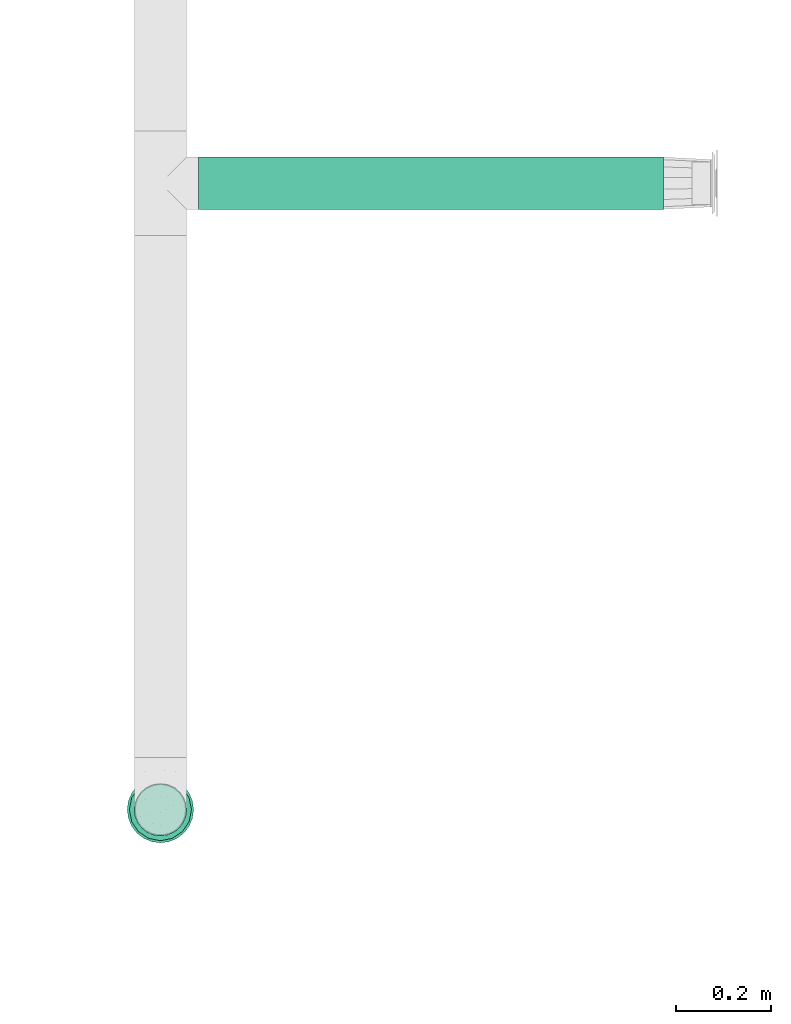
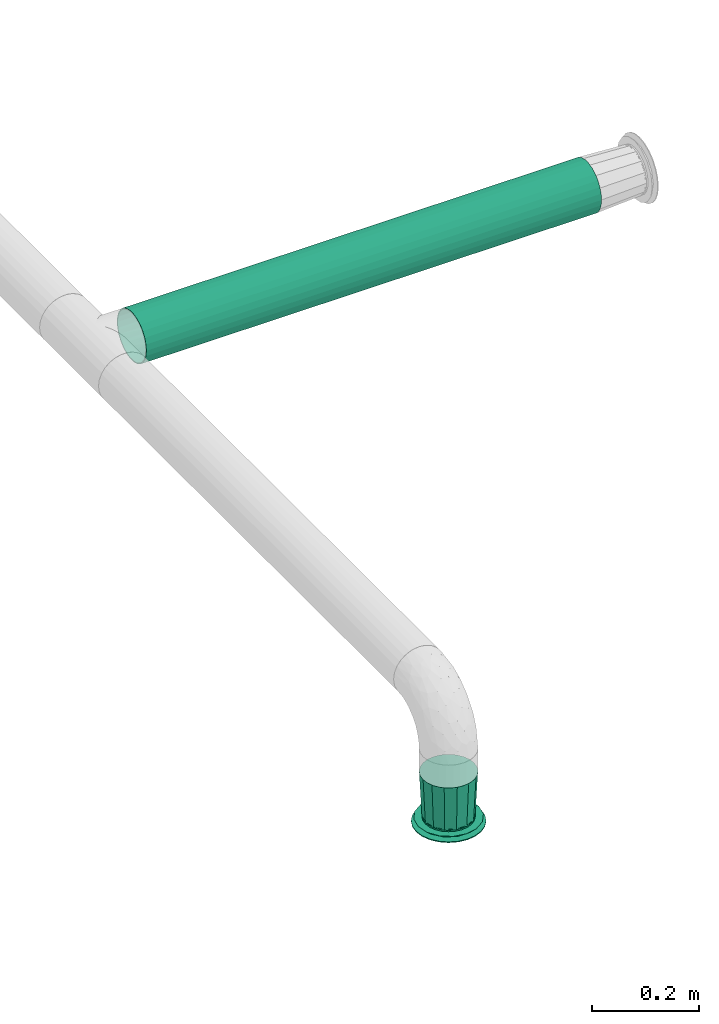
# One storey, part 80 of 115: 1 flow fitting, 1 flow segment, 1 flow terminal.
"""IFC2X3 building model written with IfcOpenShell, lengths in millimetres."""

from ifc_helpers import new_model, entity, si_unit, converted_unit, derived_unit, direction, frame, origin_with_axes, origin_2d_with_axis, place, context, subcontext, project, spatial, hollow_circle, extrude, open_shell, surface_model, source, transform, mapped, material, layer, layer_set, layer_usage, type_object, element, save


model = new_model("IFC2X3")

# Units and contexts
model_context = context("Model", 3, precision=1e-05, world=origin_with_axes(), true_north=direction((0.0, 1.0)))
body_context = subcontext(model_context, "Body", "Model", "MODEL_VIEW")
ifc_project = project(units=[si_unit("AREAUNIT", "SQUARE_METRE"), si_unit("VOLUMEUNIT", "CUBIC_METRE", prefix="DECI"), si_unit("TIMEUNIT", "SECOND"), si_unit("THERMODYNAMICTEMPERATUREUNIT", "DEGREE_CELSIUS"), si_unit("PRESSUREUNIT", "PASCAL"), si_unit("MASSUNIT", "GRAM", prefix="KILO"), si_unit("LENGTHUNIT", "METRE", prefix="MILLI"), si_unit("POWERUNIT", "WATT"), si_unit("ELECTRICCURRENTUNIT", "AMPERE"), si_unit("ELECTRICVOLTAGEUNIT", "VOLT"), derived_unit("VOLUMETRICFLOWRATEUNIT", [(si_unit("VOLUMEUNIT", "CUBIC_METRE", prefix="DECI"), 1), (si_unit("TIMEUNIT", "SECOND"), -1)]), derived_unit("LINEARVELOCITYUNIT", [(si_unit("LENGTHUNIT", "METRE"), 1), (si_unit("TIMEUNIT", "SECOND"), -1)]), derived_unit("MASSDENSITYUNIT", [(si_unit("MASSUNIT", "GRAM", prefix="KILO"), 1), (si_unit("VOLUMEUNIT", "CUBIC_METRE"), -1)]), converted_unit("PLANEANGLEUNIT", "DEGREE", entity("IfcRatioMeasure", 0.01745), si_unit("PLANEANGLEUNIT", "RADIAN"), dimensions=[0, 0, 0, 0, 0, 0, 0])], contexts=[model_context])

# Site, building, storey
site_placement = place(None, origin_with_axes())
site = spatial("IfcSite", under=ifc_project, at=site_placement, CompositionType="ELEMENT")
building_placement = place(site_placement, origin_with_axes())
building = spatial("IfcBuilding", under=site, at=building_placement, Name="mc-building", CompositionType="ELEMENT")
storey_placement = place(building_placement, frame((0.0, 0.0, 2950.0), z_axis=(0.0, 0.0, 1.0), x_axis=(1.0, 0.0, 0.0)))
storey = spatial("IfcBuildingStorey", under=building, at=storey_placement, Name="2. Korrus", CompositionType="ELEMENT", Elevation=2950.0)

# Flow terminal
air_terminal_type = type_object("IfcAirTerminalType", Name="100", PredefinedType="NOTDEFINED")
shared_shape_1 = source(origin_with_axes(), body_context, "Body", "SurfaceModel", [
    surface_model("IfcShellBasedSurfaceModel", [(11.2, -70.0, 0.0), (11.2, -67.61481, -18.11733), (11.2, -67.61481, 18.11733), (6.2, -14.64625, -20.15883), (9.2, -22.36867, -22.36867), (6.2, -21.19625, -15.39997), (9.2, 16.375, -28.36233), (6.2, 8.09625, -24.91768), (6.2, 14.64625, -20.15883), (6.2, -8.09625, -24.91768), (9.2, -16.375, -28.36233), (6.2, 21.19625, -15.39997), (9.2, 22.36867, -22.36867), (9.2, -8.1875, -30.55617), (9.2, 8.1875, -30.55617), (9.2, 28.36233, -16.375), (9.2, -28.36233, -16.375), (6.2, 14.64625, 20.15883), (9.2, 22.36867, 22.36867), (6.2, 21.19625, 15.39997), (9.2, -16.375, 28.36233), (6.2, -8.09625, 24.91768), (6.2, -14.64625, 20.15883), (6.2, 8.09625, 24.91768), (9.2, 16.375, 28.36233), (6.2, -21.19625, 15.39997), (9.2, -22.36867, 22.36867), (9.2, 8.1875, 30.55617), (9.2, -8.1875, 30.55617), (9.2, -28.36233, 16.375), (9.2, 28.36233, 16.375), (6.2, -53.11211, -25.57744), (6.2, -36.75472, -46.08897), (6.2, -13.11761, -57.472), (6.2, 13.11761, -57.472), (6.2, 36.75472, -46.08897), (6.2, 53.11211, -25.57744), (0.0, -12.53288, -63.00706), (6.2, 0.0, -57.472), (0.0, -46.3155, -46.3155), (0.0, -35.69063, -53.4148), (0.0, 0.0, -65.5), (6.2, 44.93342, -35.83321), (0.0, 46.3155, -46.3155), (0.0, 35.69063, -53.4148), (6.2, -44.93342, -35.83321), (0.0, 12.53288, -63.00706), (0.0, 25.06576, -60.51411), (6.2, 56.03105, -12.78872), (0.0, 60.51411, -25.06576), (0.0, 63.00706, -12.53288), (0.0, 53.4148, -35.69063), (0.0, -25.06576, -60.51411), (0.0, -63.00706, -12.53288), (0.0, -60.51411, -25.06576), (6.2, -56.03105, -12.78872), (0.0, -53.4148, -35.69063), (6.2, 13.11761, 57.472), (0.0, 12.53288, 63.00706), (6.2, 0.0, 57.472), (6.2, 36.75472, 46.08897), (0.0, 46.3155, 46.3155), (0.0, 35.69063, 53.4148), (0.0, 0.0, 65.5), (6.2, -44.93342, 35.83321), (6.2, -36.75472, 46.08897), (0.0, -46.3155, 46.3155), (0.0, -35.69063, 53.4148), (6.2, 44.93342, 35.83321), (0.0, -12.53288, 63.00706), (0.0, -25.06576, 60.51411), (6.2, -13.11761, 57.472), (6.2, -56.03105, 12.78872), (0.0, -60.51411, 25.06576), (0.0, -63.00706, 12.53288), (0.0, -53.4148, 35.69063), (0.0, 25.06576, 60.51411), (0.0, 63.00706, 12.53288), (0.0, 60.51411, 25.06576), (6.2, 56.03105, 12.78872), (0.0, 53.4148, 35.69063), (-3.1, 43.30127, 25.0), (-3.1, -48.29629, -12.94095), (-3.1, -43.30127, 25.0), (-3.1, 25.0, -43.30127), (-3.1, 48.29629, -12.94095), (-3.1, 35.35534, -35.35534), (-3.1, -35.35534, -35.35534), (-3.1, -25.0, -43.30127), (-43.1, 43.46666, 11.64686), (-3.1, 38.97115, 22.5), (-3.1, 43.46666, 11.64686), (-3.1, 45.0, 0.0), (-43.1, 45.0, 0.0), (-3.1, 31.81981, 31.81981), (-43.1, 38.97115, 22.5), (-43.1, -38.97115, 22.5), (-3.1, -38.97115, 22.5), (-3.1, -31.81981, 31.81981), (-3.1, -43.46666, 11.64686), (-43.1, -43.46666, 11.64686), (-43.1, -45.0, 0.0), (-3.1, -45.0, 0.0), (-43.1, -43.46666, -11.64686), (-3.1, -38.97115, -22.5), (-3.1, -43.46666, -11.64686), (-3.1, -11.64686, -43.46666), (-3.1, -22.5, -38.97115), (-43.1, -22.5, -38.97115), (-3.1, -31.81981, -31.81981), (-43.1, -38.97115, -22.5), (-43.1, 22.5, -38.97115), (-3.1, 22.5, -38.97115), (-3.1, 11.64686, -43.46666), (-43.1, 38.97115, -22.5), (-3.1, 38.97115, -22.5), (-3.1, 31.81981, -31.81981), (-3.1, 43.46666, -11.64686), (-43.1, 43.46666, -11.64686), (11.2, -49.49747, -49.49747), (11.2, -35.0, -60.62178), (11.2, -18.11733, -67.61481), (11.2, 67.61481, 18.11733), (11.2, -60.62178, -35.0), (11.2, 18.11733, -67.61481), (11.2, 35.0, -60.62178), (11.2, 0.0, -70.0), (11.2, 60.62178, -35.0), (11.2, 67.61481, -18.11733), (11.2, 49.49747, -49.49747), (11.2, -49.49747, 49.49747), (11.2, -60.62178, 35.0), (11.2, -35.0, 60.62178), (11.2, -18.11733, 67.61481), (11.2, 0.0, 70.0), (11.2, 60.62178, 35.0), (11.2, 49.49747, 49.49747), (11.2, 70.0, 0.0), (11.2, 35.0, 60.62178), (11.2, 18.11733, 67.61481), (9.2, -49.49747, 49.49747), (9.2, -35.0, 60.62178), (9.2, -18.11733, 67.61481), (9.2, -67.61481, 18.11733), (9.2, -70.0, 0.0), (9.2, -60.62178, 35.0), (9.2, 67.61481, 18.11733), (9.2, 35.0, 60.62178), (9.2, 18.11733, 67.61481), (9.2, 0.0, 70.0), (9.2, 60.62178, 35.0), (9.2, 49.49747, 49.49747), (9.2, -67.61481, -18.11733), (9.2, -49.49747, -49.49747), (9.2, -60.62178, -35.0), (9.2, -18.11733, -67.61481), (9.2, 70.0, 0.0), (9.2, -35.0, -60.62178), (9.2, 0.0, -70.0), (9.2, 60.62178, -35.0), (9.2, 49.49747, -49.49747), (9.2, 67.61481, -18.11733), (9.2, 35.0, -60.62178), (9.2, 18.11733, -67.61481), (9.2, -32.75, 0.0), (9.2, 0.0, 32.75), (9.2, 32.75, 0.0), (9.2, 0.0, -32.75), (6.2, 26.2, 0.0), (6.2, -26.2, 0.0), (9.2, -31.06579, -6.28555), (6.2, -23.69812, -7.69999), (6.2, 23.69812, -7.69999), (9.2, 31.06579, -6.28555), (6.2, 0.0, -24.91768), (9.2, 31.06579, 6.28555), (6.2, 23.69812, 7.69999), (6.2, -23.69812, 7.69999), (9.2, -31.06579, 6.28555), (6.2, 0.0, 24.91768), (6.2, 53.11211, 25.57744), (6.2, 58.95, 0.0), (6.2, -53.11211, 25.57744), (6.2, -58.95, 0.0), (0.0, 65.5, 0.0), (0.0, -65.5, 0.0), (6.2, -24.93616, -51.78048), (6.2, 24.93616, -51.78048), (6.2, 24.93616, 51.78048), (6.2, -24.93616, 51.78048), (-3.1, 0.0, 50.0), (-3.1, 35.35534, 35.35534), (-3.1, -12.94095, 48.29629), (-3.1, -25.0, 43.30127), (-3.1, -35.35534, 35.35534), (-3.1, 25.0, 43.30127), (-3.1, 12.94095, 48.29629), (-3.1, 48.29629, 12.94095), (-3.1, 50.0, 0.0), (-3.1, -50.0, 0.0), (-3.1, -48.29629, 12.94095), (-3.1, -43.30127, -25.0), (-3.1, -12.94095, -48.29629), (-3.1, 0.0, -50.0), (-3.1, 43.30127, -25.0), (-3.1, 12.94095, -48.29629), (0.0, -12.94095, -48.29629), (0.0, 0.0, -50.0), (0.0, -25.0, -43.30127), (0.0, -35.35534, -35.35534), (0.0, -48.29629, -12.94095), (0.0, 25.0, -43.30127), (0.0, -43.30127, -25.0), (0.0, 43.30127, 25.0), (0.0, 12.94095, -48.29629), (0.0, 43.30127, -25.0), (0.0, 48.29629, -12.94095), (0.0, 35.35534, -35.35534), (0.0, 50.0, 0.0), (0.0, -50.0, 0.0), (0.0, -48.29629, 12.94095), (0.0, -43.30127, 25.0), (0.0, -35.35534, 35.35534), (0.0, -12.94095, 48.29629), (0.0, -25.0, 43.30127), (0.0, 35.35534, 35.35534), (0.0, 0.0, 50.0), (0.0, 48.29629, 12.94095), (0.0, 25.0, 43.30127), (0.0, 12.94095, 48.29629), (-43.1, -22.5, 38.97115), (-43.1, -11.64686, 43.46666), (-43.1, 0.0, 45.0), (-43.1, 11.64686, 43.46666), (-43.1, -31.81981, 31.81981), (-43.1, 31.81981, 31.81981), (-43.1, 22.5, 38.97115), (-43.1, -31.81981, -31.81981), (-43.1, 31.81981, -31.81981), (-43.1, -11.64686, -43.46666), (-43.1, 11.64686, -43.46666), (-43.1, 0.0, -45.0), (-3.1, 0.0, -45.0), (-3.1, 0.0, 45.0), (-3.1, -22.5, 38.97115), (-3.1, -11.64686, 43.46666), (-3.1, 11.64686, 43.46666), (-3.1, 22.5, 38.97115)], [open_shell([[[0, 1, 2]], [[3, 4, 5]], [[6, 7, 8]], [[3, 9, 10]], [[4, 3, 10]], [[11, 12, 8]], [[13, 10, 9]], [[7, 6, 14]], [[6, 8, 12]], [[12, 11, 15]], [[16, 5, 4]], [[17, 18, 19]], [[20, 21, 22]], [[17, 23, 24]], [[18, 17, 24]], [[25, 26, 22]], [[27, 24, 23]], [[21, 20, 28]], [[20, 22, 26]], [[26, 25, 29]], [[30, 19, 18]], [[31, 32, 33]], [[34, 35, 36]], [[33, 37, 38]], [[32, 39, 40]], [[41, 38, 37]], [[42, 35, 43]], [[44, 43, 35]], [[39, 32, 45]], [[46, 47, 34]], [[48, 49, 50]], [[38, 46, 34]], [[42, 43, 51]], [[33, 52, 37]], [[53, 54, 55]], [[46, 38, 41]], [[56, 39, 45]], [[57, 58, 59]], [[60, 61, 62]], [[63, 59, 58]], [[64, 65, 66]], [[67, 66, 65]], [[61, 60, 68]], [[69, 70, 71]], [[72, 73, 74]], [[59, 69, 71]], [[64, 66, 75]], [[57, 76, 58]], [[77, 78, 79]], [[69, 59, 63]], [[80, 61, 68]], [[81, 82, 83]], [[84, 85, 86]], [[87, 82, 88]], [[89, 90, 91]], [[91, 92, 93]], [[94, 90, 95]], [[96, 97, 98]], [[99, 97, 100]], [[101, 102, 99]], [[103, 104, 105]], [[105, 102, 101]], [[106, 107, 108]], [[109, 104, 110]], [[111, 112, 113]], [[114, 115, 116]], [[117, 115, 118]], [[93, 92, 117]], [[119, 120, 121]], [[1, 119, 121]], [[122, 1, 121]], [[123, 119, 1]], [[124, 122, 121]], [[125, 122, 124]], [[121, 126, 124]], [[127, 128, 129]], [[129, 128, 122]], [[129, 122, 125]], [[130, 131, 2]], [[132, 130, 2]], [[122, 133, 2]], [[132, 2, 133]], [[134, 133, 122]], [[135, 136, 122]], [[122, 128, 137]], [[136, 138, 122]], [[139, 122, 138]], [[122, 139, 134]], [[2, 1, 122]], [[140, 141, 142]], [[143, 140, 142]], [[142, 144, 143]], [[145, 140, 143]], [[146, 144, 142]], [[147, 146, 148]], [[149, 148, 146]], [[150, 146, 151]], [[147, 151, 146]], [[146, 142, 149]], [[146, 152, 144]], [[153, 154, 152]], [[155, 153, 152]], [[146, 156, 155]], [[157, 153, 155]], [[158, 155, 156]], [[159, 160, 161]], [[156, 161, 160]], [[160, 162, 156]], [[163, 156, 162]], [[163, 158, 156]], [[152, 146, 155]], [[156, 128, 161]], [[161, 127, 159]], [[162, 160, 125]], [[129, 160, 159]], [[163, 162, 124]], [[128, 127, 161]], [[156, 137, 128]], [[162, 125, 124]], [[125, 160, 129]], [[159, 127, 129]], [[163, 124, 126]], [[126, 158, 163]], [[158, 121, 155]], [[155, 120, 157]], [[154, 153, 123]], [[119, 153, 157]], [[152, 154, 1]], [[120, 119, 157]], [[155, 121, 120]], [[152, 1, 0]], [[1, 154, 123]], [[153, 119, 123]], [[152, 0, 144]], [[126, 121, 158]], [[144, 2, 143]], [[143, 131, 145]], [[141, 140, 132]], [[130, 140, 145]], [[142, 141, 133]], [[2, 131, 143]], [[144, 0, 2]], [[141, 132, 133]], [[132, 140, 130]], [[145, 131, 130]], [[142, 133, 134]], [[134, 149, 142]], [[149, 139, 148]], [[148, 138, 147]], [[150, 151, 135]], [[136, 151, 147]], [[146, 150, 122]], [[138, 136, 147]], [[148, 139, 138]], [[146, 122, 137]], [[122, 150, 135]], [[151, 136, 135]], [[146, 137, 156]], [[134, 139, 149]], [[30, 24, 164]], [[24, 20, 164]], [[165, 20, 24]], [[164, 20, 29]], [[166, 30, 16]], [[16, 6, 166]], [[167, 6, 10]], [[30, 164, 16]], [[10, 6, 16]], [[6, 15, 166]], [[21, 19, 11]], [[23, 19, 21]], [[11, 19, 168]], [[7, 25, 21]], [[7, 5, 169]], [[21, 11, 7]], [[9, 5, 7]], [[169, 25, 7]], [[170, 164, 169]], [[170, 171, 16]], [[11, 172, 15]], [[172, 168, 173]], [[174, 13, 9]], [[166, 173, 168]], [[172, 173, 15]], [[169, 171, 170]], [[5, 16, 171]], [[167, 174, 14]], [[174, 167, 13]], [[14, 174, 7]], [[175, 166, 168]], [[175, 176, 30]], [[25, 177, 29]], [[177, 169, 178]], [[179, 27, 23]], [[164, 178, 169]], [[177, 178, 29]], [[168, 176, 175]], [[19, 30, 176]], [[165, 179, 28]], [[179, 165, 27]], [[28, 179, 21]], [[180, 60, 57]], [[181, 180, 65]], [[65, 57, 71]], [[180, 57, 65]], [[65, 182, 181]], [[182, 36, 181]], [[183, 34, 36]], [[31, 34, 183]], [[31, 33, 34]], [[182, 183, 36]], [[70, 63, 49]], [[70, 73, 66]], [[49, 63, 184]], [[78, 76, 61]], [[76, 78, 184]], [[184, 63, 76]], [[73, 70, 49]], [[39, 54, 185]], [[41, 39, 185]], [[52, 39, 41]], [[43, 185, 49]], [[185, 43, 47]], [[185, 47, 41]], [[73, 49, 185]], [[55, 54, 31]], [[31, 54, 56]], [[52, 186, 40]], [[53, 55, 183]], [[56, 45, 31]], [[185, 53, 183]], [[32, 40, 186]], [[33, 186, 52]], [[44, 35, 187]], [[49, 36, 51]], [[34, 47, 187]], [[42, 51, 36]], [[187, 47, 44]], [[49, 48, 36]], [[48, 50, 181]], [[184, 181, 50]], [[79, 78, 180]], [[180, 78, 80]], [[76, 188, 62]], [[77, 79, 181]], [[80, 68, 180]], [[184, 77, 181]], [[60, 62, 188]], [[57, 188, 76]], [[67, 65, 189]], [[73, 182, 75]], [[71, 70, 189]], [[64, 75, 182]], [[189, 70, 67]], [[73, 72, 182]], [[72, 74, 183]], [[185, 183, 74]], [[190, 191, 192]], [[193, 192, 194]], [[83, 192, 81]], [[194, 192, 83]], [[195, 191, 196]], [[191, 190, 196]], [[197, 198, 81]], [[81, 192, 191]], [[198, 84, 81]], [[199, 200, 83]], [[81, 88, 82]], [[201, 82, 87]], [[88, 81, 202]], [[81, 203, 202]], [[204, 86, 85]], [[205, 203, 84]], [[84, 198, 85]], [[81, 84, 203]], [[199, 83, 82]], [[206, 207, 208]], [[209, 208, 210]], [[210, 208, 211]], [[212, 209, 210]], [[210, 211, 213]], [[214, 211, 207]], [[211, 208, 207]], [[215, 216, 217]], [[211, 217, 216]], [[216, 218, 211]], [[219, 210, 220]], [[221, 210, 213]], [[222, 221, 223]], [[213, 223, 221]], [[224, 222, 223]], [[223, 225, 226]], [[227, 213, 218]], [[218, 213, 211]], [[228, 229, 225]], [[223, 213, 225]], [[226, 225, 229]], [[221, 220, 210]], [[199, 220, 200]], [[200, 221, 83]], [[193, 194, 224]], [[222, 194, 83]], [[192, 193, 223]], [[220, 221, 200]], [[199, 219, 220]], [[193, 224, 223]], [[224, 194, 222]], [[83, 221, 222]], [[192, 223, 226]], [[226, 190, 192]], [[190, 229, 196]], [[196, 228, 195]], [[81, 191, 213]], [[225, 191, 195]], [[197, 81, 227]], [[228, 225, 195]], [[196, 229, 228]], [[197, 227, 218]], [[227, 81, 213]], [[191, 225, 213]], [[197, 218, 198]], [[226, 229, 190]], [[198, 216, 85]], [[85, 215, 204]], [[84, 86, 211]], [[217, 86, 204]], [[205, 84, 214]], [[216, 215, 85]], [[198, 218, 216]], [[84, 211, 214]], [[211, 86, 217]], [[204, 215, 217]], [[205, 214, 207]], [[207, 203, 205]], [[203, 206, 202]], [[202, 208, 88]], [[201, 87, 212]], [[209, 87, 88]], [[82, 201, 210]], [[208, 209, 88]], [[202, 206, 208]], [[82, 210, 219]], [[210, 201, 212]], [[87, 209, 212]], [[82, 219, 199]], [[207, 206, 203]], [[230, 231, 232]], [[230, 232, 233]], [[230, 100, 96]], [[234, 230, 96]], [[100, 230, 233]], [[235, 89, 236]], [[100, 233, 236]], [[95, 89, 235]], [[118, 89, 93]], [[118, 236, 89]], [[118, 100, 236]], [[110, 103, 101]], [[237, 110, 101]], [[238, 108, 101]], [[237, 101, 108]], [[239, 108, 238]], [[114, 238, 118]], [[238, 101, 118]], [[240, 241, 111]], [[238, 111, 241]], [[238, 241, 239]], [[100, 118, 101]], [[106, 242, 107]], [[107, 112, 109]], [[102, 105, 104]], [[112, 104, 109]], [[92, 104, 117]], [[113, 112, 242]], [[112, 107, 242]], [[115, 117, 116]], [[112, 116, 117]], [[112, 117, 104]], [[92, 102, 104]], [[97, 99, 243]], [[98, 97, 244]], [[243, 245, 244]], [[97, 243, 244]], [[246, 243, 99]], [[90, 94, 91]], [[92, 91, 247]], [[94, 247, 91]], [[247, 99, 92]], [[247, 246, 99]], [[102, 92, 99]], [[101, 99, 100]], [[100, 97, 96]], [[230, 234, 244]], [[98, 234, 96]], [[231, 230, 245]], [[245, 230, 244]], [[244, 234, 98]], [[245, 243, 231]], [[243, 232, 231]], [[236, 233, 246]], [[236, 247, 235]], [[89, 95, 90]], [[94, 95, 235]], [[93, 89, 91]], [[232, 246, 233]], [[246, 247, 236]], [[243, 246, 232]], [[247, 94, 235]], [[93, 117, 118]], [[118, 115, 114]], [[111, 238, 112]], [[116, 238, 114]], [[240, 111, 113]], [[112, 238, 116]], [[240, 113, 242]], [[242, 241, 240]], [[108, 239, 106]], [[108, 107, 237]], [[103, 110, 104]], [[109, 110, 237]], [[101, 103, 105]], [[241, 106, 239]], [[242, 106, 241]], [[107, 109, 237]]])]),
])
flow_terminal_placement = place(storey_placement, frame((18604.54349, 8183.57591, 2200.0), z_axis=(0.0, 1.0, 0.0), x_axis=(0.0, 0.0, -1.0)))
element("IfcFlowTerminal", 1, at=flow_terminal_placement, inside=storey, type_object=air_terminal_type, Name="100", context=body_context, shape_type="MappedRepresentation", body=[
    mapped(shared_shape_1, transform((0.0, 0.0, 0.0), scale=1.0)),
])

# Flow fitting
duct_fitting_type = type_object("IfcDuctFittingType", PredefinedType="TRANSITION")
shared_shape_2 = source(origin_with_axes(), body_context, "Body", "SurfaceModel", [
    surface_model("IfcShellBasedSurfaceModel", [(100.0, -55.0, 0.0), (100.0, -12.23865, 53.62104), (100.0, -34.29194, 43.00073), (100.0, 49.55329, 23.86361), (100.0, 34.29194, 43.00073), (100.0, 49.55329, -23.86361), (0.0, -45.04844, -21.69419), (0.0, -50.0, 0.0), (0.0, -45.04844, 21.69419), (0.0, 31.17449, 39.09157), (0.0, 45.04844, 21.69419), (0.0, 50.0, 0.0), (98.0, 47.63139, 27.5), (98.0, 0.0, 55.0), (98.0, 38.89087, 38.89087), (98.0, -38.89087, 38.89087), (98.0, -47.63139, 27.5), (100.0, 12.23865, 53.62104), (100.0, -49.55329, 23.86361), (100.0, 55.0, 0.0), (100.0, 12.23865, -53.62104), (100.0, 34.29194, -43.00073), (100.0, -49.55329, -23.86361), (100.0, -34.29194, -43.00073), (100.0, -12.23865, -53.62104), (0.0, -31.17449, 39.09157), (0.0, -11.12605, 48.7464), (0.0, 11.12605, 48.7464), (0.0, -31.17449, -39.09157), (0.0, 11.12605, -48.7464), (0.0, -11.12605, -48.7464), (0.0, 45.04844, -21.69419), (0.0, 31.17449, -39.09157), (0.0, 47.52422, -10.84709), (0.0, 38.11147, -30.39288), (100.0, 41.92261, -33.43217), (100.0, -41.92261, -33.43217), (0.0, -38.11147, -30.39288), (100.0, 23.2653, -48.31088), (0.0, 21.15027, -43.91899), (100.0, 52.32388, -11.72483), (0.0, 0.0, -48.7464), (100.0, 0.0, -53.62104), (0.0, -21.15027, -43.91899), (100.0, -23.2653, -48.31088), (0.0, -47.52422, -10.84709), (100.0, -52.32388, -11.72483), (0.0, -47.52422, 10.84709), (0.0, -38.11147, 30.39288), (100.0, -41.92261, 33.43217), (100.0, 41.92261, 33.43217), (0.0, 38.11147, 30.39288), (100.0, -23.2653, 48.31088), (0.0, -21.15027, 43.91899), (100.0, -52.32388, 11.72483), (0.0, 0.0, 48.7464), (100.0, 0.0, 53.62104), (0.0, 21.15027, 43.91899), (100.0, 23.2653, 48.31088), (0.0, 47.52422, 10.84709), (100.0, 52.32388, 11.72483), (100.0, -14.23505, -53.12592), (100.0, 0.0, -55.0), (100.0, -27.5, -47.63139), (100.0, 27.5, -47.63139), (100.0, -38.89087, -38.89087), (100.0, -53.12592, -14.23505), (100.0, -47.63139, -27.5), (100.0, -47.63139, 27.5), (100.0, 14.23505, -53.12592), (100.0, 38.89087, -38.89087), (100.0, 47.63139, -27.5), (100.0, 47.63139, 27.5), (100.0, 53.12592, -14.23505), (100.0, -53.12592, 14.23505), (100.0, -38.89087, 38.89087), (100.0, -27.5, 47.63139), (100.0, 0.0, 55.0), (100.0, -14.23505, 53.12592), (100.0, 53.12592, 14.23505), (100.0, 38.89087, 38.89087), (100.0, 27.5, 47.63139), (100.0, 14.23505, 53.12592), (98.0, -27.5, 47.63139), (98.0, -14.23505, 53.12592), (98.0, -53.12592, -14.23505), (98.0, 14.23505, 53.12592), (98.0, 27.5, 47.63139), (98.0, 53.12592, 14.23505), (98.0, 55.0, 0.0), (98.0, -47.63139, -27.5), (98.0, -53.12592, 14.23505), (98.0, 27.5, -47.63139), (98.0, -27.5, -47.63139), (98.0, -38.89087, -38.89087), (98.0, 0.0, -55.0), (98.0, -14.23505, -53.12592), (98.0, 38.89087, -38.89087), (98.0, 47.63139, -27.5), (98.0, 53.12592, -14.23505), (98.0, 14.23505, -53.12592), (98.0, -55.0, 0.0), (0.0, 0.0, 50.0), (0.0, 35.35534, 35.35534), (0.0, -12.94095, 48.29629), (0.0, -25.0, 43.30127), (0.0, -35.35534, 35.35534), (0.0, -48.29629, 12.94095), (0.0, -43.30127, 25.0), (0.0, 25.0, 43.30127), (0.0, 12.94095, 48.29629), (0.0, 43.30127, 25.0), (0.0, 48.29629, 12.94095), (0.0, 25.0, -43.30127), (0.0, 48.29629, -12.94095), (0.0, -48.29629, -12.94095), (0.0, -43.30127, -25.0), (0.0, -12.94095, -48.29629), (0.0, -25.0, -43.30127), (0.0, -35.35534, -35.35534), (0.0, 43.30127, -25.0), (0.0, 35.35534, -35.35534), (0.0, 12.94095, -48.29629), (0.0, 0.0, -50.0), (2.0, -35.35534, -35.35534), (2.0, -25.0, -43.30127), (2.0, -12.94095, -48.29629), (2.0, -43.30127, -25.0), (2.0, 0.0, -50.0), (2.0, -48.29629, -12.94095), (2.0, -50.0, 0.0), (2.0, 12.94095, -48.29629), (2.0, 25.0, -43.30127), (2.0, 43.30127, -25.0), (2.0, 48.29629, -12.94095), (2.0, 35.35534, -35.35534), (2.0, -48.29629, 12.94095), (2.0, -35.35534, 35.35534), (2.0, -43.30127, 25.0), (2.0, 35.35534, 35.35534), (2.0, -12.94095, 48.29629), (2.0, -25.0, 43.30127), (2.0, 0.0, 50.0), (2.0, 43.30127, 25.0), (2.0, 48.29629, 12.94095), (2.0, 50.0, 0.0), (2.0, 25.0, 43.30127), (2.0, 12.94095, 48.29629)], [open_shell([[[0, 1, 2]], [[3, 4, 5]], [[6, 7, 8]], [[9, 10, 11]], [[12, 13, 14]], [[15, 13, 16]], [[0, 4, 17]], [[2, 18, 0]], [[1, 0, 17]], [[3, 5, 19]], [[20, 21, 5]], [[22, 20, 5]], [[22, 5, 0]], [[22, 23, 24]], [[22, 24, 20]], [[4, 0, 5]], [[8, 25, 6]], [[6, 25, 26]], [[6, 26, 27]], [[11, 27, 9]], [[28, 6, 29]], [[30, 28, 29]], [[31, 6, 11]], [[31, 32, 29]], [[31, 29, 6]], [[27, 11, 6]], [[31, 33, 5]], [[34, 35, 32]], [[36, 22, 6]], [[36, 37, 23]], [[38, 29, 39]], [[33, 40, 5]], [[33, 11, 40]], [[19, 40, 11]], [[32, 21, 39]], [[32, 35, 21]], [[34, 31, 35]], [[30, 41, 42]], [[28, 43, 44]], [[42, 41, 20]], [[7, 45, 46]], [[38, 39, 21]], [[46, 0, 7]], [[6, 37, 36]], [[38, 20, 29]], [[43, 30, 24]], [[42, 24, 30]], [[28, 23, 37]], [[6, 22, 45]], [[35, 31, 5]], [[44, 43, 24]], [[20, 41, 29]], [[46, 45, 22]], [[44, 23, 28]], [[8, 47, 18]], [[48, 49, 25]], [[50, 3, 10]], [[50, 51, 4]], [[52, 26, 53]], [[47, 54, 18]], [[47, 7, 54]], [[0, 54, 7]], [[25, 2, 53]], [[25, 49, 2]], [[48, 8, 49]], [[27, 55, 56]], [[9, 57, 58]], [[56, 55, 1]], [[11, 59, 60]], [[52, 53, 2]], [[60, 19, 11]], [[10, 51, 50]], [[52, 1, 26]], [[57, 27, 17]], [[56, 17, 27]], [[9, 4, 51]], [[10, 3, 59]], [[49, 8, 18]], [[58, 57, 17]], [[1, 55, 26]], [[60, 59, 3]], [[58, 4, 9]], [[61, 62, 63]], [[63, 64, 65]], [[66, 67, 68]], [[65, 64, 67]], [[67, 64, 68]], [[69, 64, 62]], [[64, 63, 62]], [[70, 71, 64]], [[72, 64, 71]], [[71, 73, 19]], [[74, 0, 66]], [[72, 68, 64]], [[75, 68, 76]], [[77, 78, 76]], [[72, 76, 68]], [[76, 72, 77]], [[79, 72, 19]], [[19, 72, 71]], [[80, 81, 77]], [[77, 72, 80]], [[82, 77, 81]], [[74, 66, 68]], [[83, 84, 13]], [[15, 83, 13]], [[12, 16, 13]], [[16, 12, 85]], [[86, 87, 13]], [[87, 14, 13]], [[88, 89, 12]], [[89, 90, 12]], [[91, 16, 85]], [[90, 85, 12]], [[89, 92, 90]], [[93, 94, 95]], [[95, 94, 90]], [[96, 93, 95]], [[97, 92, 98]], [[98, 89, 99]], [[100, 95, 92]], [[92, 89, 98]], [[90, 92, 95]], [[101, 91, 85]], [[89, 73, 99]], [[99, 71, 98]], [[92, 97, 64]], [[70, 97, 98]], [[100, 92, 69]], [[73, 71, 99]], [[89, 19, 73]], [[92, 64, 69]], [[64, 97, 70]], [[98, 71, 70]], [[100, 69, 62]], [[62, 95, 100]], [[95, 61, 96]], [[96, 63, 93]], [[90, 94, 67]], [[65, 94, 93]], [[85, 90, 66]], [[63, 65, 93]], [[96, 61, 63]], [[85, 66, 0]], [[66, 90, 67]], [[94, 65, 67]], [[85, 0, 101]], [[62, 61, 95]], [[101, 74, 91]], [[91, 68, 16]], [[83, 15, 76]], [[75, 15, 16]], [[84, 83, 78]], [[74, 68, 91]], [[101, 0, 74]], [[83, 76, 78]], [[76, 15, 75]], [[16, 68, 75]], [[84, 78, 77]], [[77, 13, 84]], [[13, 82, 86]], [[86, 81, 87]], [[12, 14, 72]], [[80, 14, 87]], [[88, 12, 79]], [[81, 80, 87]], [[86, 82, 81]], [[88, 79, 19]], [[79, 12, 72]], [[14, 80, 72]], [[88, 19, 89]], [[77, 82, 13]], [[102, 103, 104]], [[105, 104, 106]], [[107, 108, 106]], [[103, 106, 104]], [[106, 103, 107]], [[109, 103, 110]], [[103, 102, 110]], [[111, 112, 103]], [[113, 103, 112]], [[112, 11, 114]], [[107, 103, 113]], [[113, 115, 107]], [[116, 115, 117]], [[117, 118, 119]], [[116, 117, 119]], [[117, 115, 113]], [[120, 121, 114]], [[113, 114, 121]], [[113, 122, 117]], [[113, 112, 114]], [[117, 122, 123]], [[7, 107, 115]], [[124, 125, 126]], [[127, 124, 126]], [[128, 129, 126]], [[127, 126, 129]], [[130, 129, 128]], [[131, 132, 128]], [[132, 130, 128]], [[133, 134, 135]], [[132, 135, 134]], [[132, 134, 130]], [[134, 136, 130]], [[137, 138, 136]], [[137, 136, 139]], [[140, 137, 139]], [[141, 137, 140]], [[142, 140, 139]], [[143, 139, 144]], [[144, 134, 145]], [[146, 147, 139]], [[139, 136, 144]], [[139, 147, 142]], [[136, 134, 144]], [[11, 134, 114]], [[114, 133, 120]], [[113, 121, 132]], [[135, 121, 120]], [[122, 113, 131]], [[134, 133, 114]], [[11, 145, 134]], [[113, 132, 131]], [[132, 121, 135]], [[120, 133, 135]], [[122, 131, 128]], [[128, 123, 122]], [[123, 126, 117]], [[117, 125, 118]], [[116, 119, 127]], [[124, 119, 118]], [[115, 116, 129]], [[125, 124, 118]], [[117, 126, 125]], [[115, 129, 130]], [[129, 116, 127]], [[119, 124, 127]], [[115, 130, 7]], [[128, 126, 123]], [[7, 136, 107]], [[107, 138, 108]], [[105, 106, 141]], [[137, 106, 108]], [[104, 105, 140]], [[136, 138, 107]], [[7, 130, 136]], [[105, 141, 140]], [[141, 106, 137]], [[108, 138, 137]], [[104, 140, 142]], [[142, 102, 104]], [[102, 147, 110]], [[110, 146, 109]], [[111, 103, 143]], [[139, 103, 109]], [[112, 111, 144]], [[146, 139, 109]], [[110, 147, 146]], [[112, 144, 145]], [[144, 111, 143]], [[103, 139, 143]], [[112, 145, 11]], [[142, 147, 102]]])]),
])
flow_fitting_placement = place(storey_placement, frame((18604.54349, 8183.57591, 2203.1), z_axis=(0.0, 1.0, 0.0), x_axis=(0.0, 0.0, 1.0)))
element("IfcFlowFitting", 2, at=flow_fitting_placement, inside=storey, type_object=duct_fitting_type, context=body_context, shape_type="MappedRepresentation", body=[
    mapped(shared_shape_2, transform((0.0, 0.0, 0.0), scale=1.0)),
])

# Flow segment
ifc_material = material(Name="FZ1")
ifc_layer = layer(ifc_material, 0.0)
ifc_layer_set = layer_set([ifc_layer], Name="FZ1")
ifc_layer_usage = layer_usage(ifc_layer_set, "AXIS1", "POSITIVE", 0.0)
duct_segment_type = type_object("IfcDuctSegmentType", PredefinedType="RIGIDSEGMENT")
shared_shape_3 = source(origin_with_axes(), body_context, "Body", "SweptSolid", [
    extrude(hollow_circle(Radius=55.0, WallThickness=2.0, at=origin_2d_with_axis()), frame((0.0, 0.0, 0.0), z_axis=(1.0, 0.0, 0.0), x_axis=(0.0, 1.0, 0.0)), (0.0, 0.0, 1.0), 980.9),
])
flow_segment_placement = place(storey_placement, frame((18684.54349, 9505.0, 2465.0), z_axis=(0.0, 0.0, 1.0), x_axis=(1.0, 0.0, 0.0)))
element("IfcFlowSegment", 3, at=flow_segment_placement, inside=storey, type_object=duct_segment_type, material=ifc_layer_usage, context=body_context, shape_type="MappedRepresentation", body=[
    mapped(shared_shape_3, transform((0.0, 0.0, 0.0), scale=1.0)),
])

save(model, "model.ifc")
